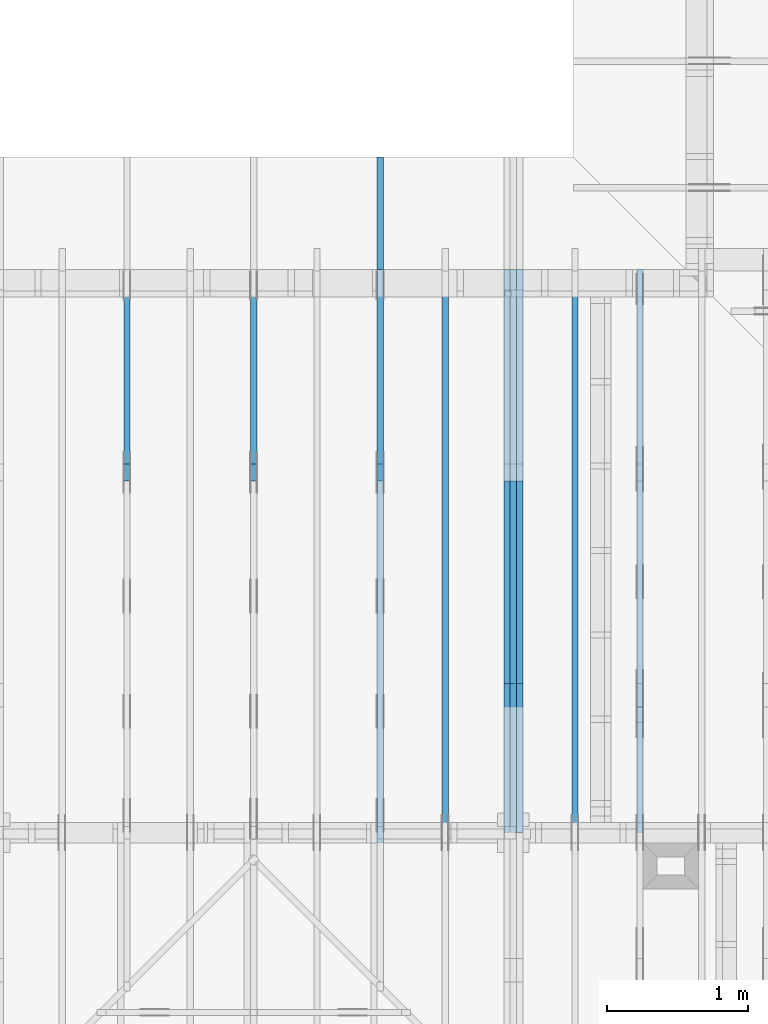
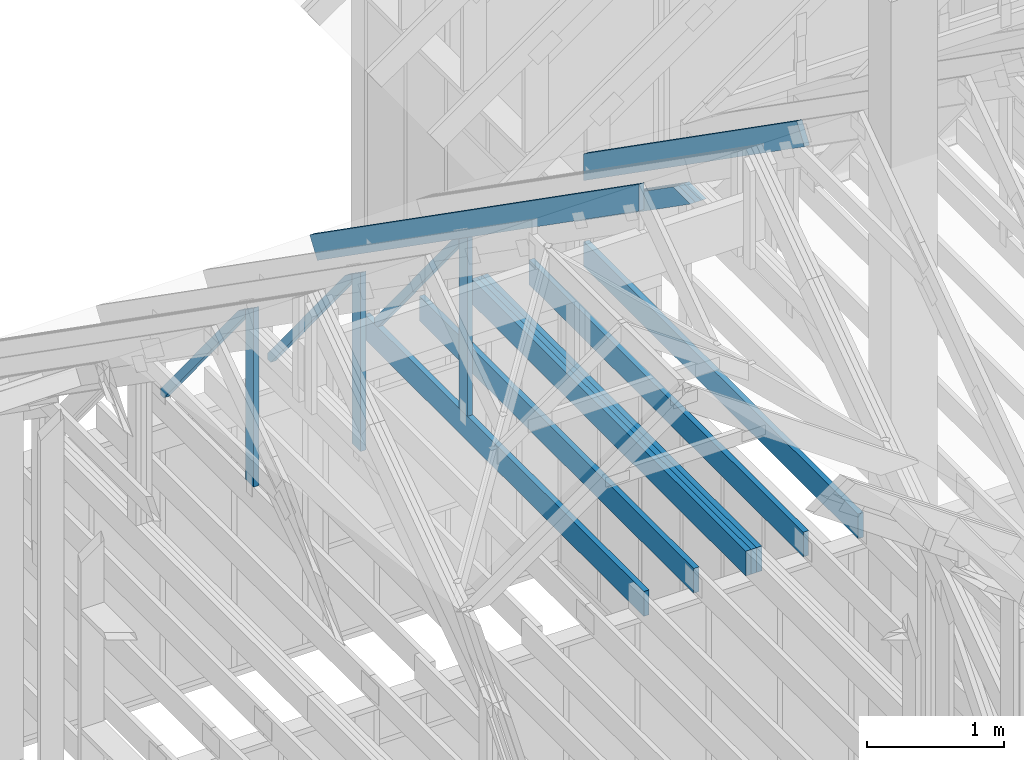
# One storey, part 17 of 70: 18 members, 7 elements without a shape of their own.
"""IFC2X3 building model written with IfcOpenShell, lengths in millimetres."""

from ifc_helpers import new_model, si_unit, frame, origin, origin_with_axes, origin_2d, place, context, project, spatial, faceted_brep, element, aggregate, save


model = new_model("IFC2X3")

# Units and contexts
model_context = context("Model", 3, precision=1e-05, world=origin())
plan_context = context("Plan", 2, precision=1e-05, world=origin_2d())
ifc_project = project(units=[si_unit("LENGTHUNIT", "METRE", prefix="MILLI"), si_unit("AREAUNIT", "SQUARE_METRE"), si_unit("VOLUMEUNIT", "CUBIC_METRE"), si_unit("SOLIDANGLEUNIT", "STERADIAN"), si_unit("PLANEANGLEUNIT", "RADIAN"), si_unit("MASSUNIT", "GRAM"), si_unit("TIMEUNIT", "SECOND"), si_unit("THERMODYNAMICTEMPERATUREUNIT", "DEGREE_CELSIUS"), si_unit("LUMINOUSINTENSITYUNIT", "LUMEN")], contexts=[model_context, plan_context])

# Site, building, storey
site_placement = place(None, origin_with_axes())
site = spatial("IfcSite", under=ifc_project, at=site_placement, CompositionType="ELEMENT")
building_placement = place(site_placement, origin_with_axes())
building = spatial("IfcBuilding", under=site, at=building_placement, Name="Layout 1", CompositionType="ELEMENT")
storey_placement = place(building_placement, origin_with_axes())
storey = spatial("IfcBuildingStorey", under=building, at=storey_placement, Name="Storey 1", CompositionType="ELEMENT", Elevation=0.0)

# Assembly, members
assembly_1_placement = place(storey_placement, frame((5660.000000000293, 8000.0, 9.122500660690286e-13), z_axis=(-1.0, 1.836909530733566e-16, 6.123031769111886e-17), x_axis=(-1.836909530733566e-16, -1.0, 0.0)))
assembly_1 = element("IfcElementAssembly", 1, at=assembly_1_placement, inside=storey, Name="T11", AssemblyPlace="FACTORY", PredefinedType="TRUSS")
member_1_placement = place(assembly_1_placement, frame((3999.9999999999995, 219.99999999999994, -90.0), z_axis=(0.0, 0.0, 1.0), x_axis=(-1.0, 1.2246063538223773e-16, 0.0)))
member_1 = element("IfcMember", 2, at=member_1_placement, Name="B3", context=model_context, shape_type="Brep", body=[
    faceted_brep([(3999.9999999999995, 220.00000000000043, 45.0), (0.0, 220.00000000000043, 45.0), (0.0, 0.0, 45.0), (4000.0, 0.0, 45.0), (0.0, 220.00000000000043, 0.0), (3999.9999999999995, 220.00000000000043, 4.898425415289508e-13), (4000.0, 0.0, 4.898425415289509e-13), (0.0, 0.0, 0.0), (0.0, 0.0, 0.0), (2.755364296100349e-15, -3.3742366240998092e-31, 45.0), (2.969670408019265e-14, 220.0, 45.0), (2.69413397840923e-14, 220.0, -1.6496267940043512e-30), (4000.0, -7.347638122934264e-13, 7.109387612088872e-29), (4000.0, -7.32008447997326e-13, 45.0), (5.061354936149714e-31, 2.755364296100349e-15, 45.0), (0.0, 0.0, 0.0), (4000.0, 220.00000000000043, 5.048709793414476e-29), (4000.0, 220.00000000000043, 45.0), (4000.0, 4.263256414560601e-13, 45.0), (4000.0, 4.263256414560601e-13, 0.0), (0.0, 220.0, 0.0), (0.0, 220.0, 45.0), (3999.9999999999995, 220.00000000000065, 45.0), (3999.9999999999995, 220.00000000000065, 1.262177448353619e-29)], [[[0, 1, 2, 3]], [[4, 5, 6, 7]], [[8, 9, 10, 11]], [[12, 13, 14, 15]], [[16, 17, 18, 19]], [[20, 21, 22, 23]]]),
])
member_2_placement = place(assembly_1_placement, frame((3999.9999999999995, 219.99999999999994, -135.0), z_axis=(0.0, 0.0, 1.0), x_axis=(-1.0, 1.2246063538223773e-16, 0.0)))
member_2 = element("IfcMember", 3, at=member_2_placement, Name="B3", context=model_context, shape_type="Brep", body=[
    faceted_brep([(3999.9999999999995, 220.00000000000043, 45.0), (0.0, 220.00000000000043, 45.0), (0.0, 0.0, 45.0), (4000.0, 0.0, 45.0), (0.0, 220.00000000000043, 0.0), (3999.9999999999995, 220.00000000000043, 4.898425415289508e-13), (4000.0, 0.0, 4.898425415289509e-13), (0.0, 0.0, 0.0), (0.0, 0.0, 0.0), (2.755364296100349e-15, -3.3742366240998092e-31, 45.0), (2.969670408019265e-14, 220.0, 45.0), (2.69413397840923e-14, 220.0, -1.6496267940043512e-30), (4000.0, -7.347638122934264e-13, 7.109387612088872e-29), (4000.0, -7.32008447997326e-13, 45.0), (5.061354936149714e-31, 2.755364296100349e-15, 45.0), (0.0, 0.0, 0.0), (4000.0, 220.00000000000043, 5.048709793414476e-29), (4000.0, 220.00000000000043, 45.0), (4000.0, 4.263256414560601e-13, 45.0), (4000.0, 4.263256414560601e-13, 0.0), (0.0, 220.0, 0.0), (0.0, 220.0, 45.0), (3999.9999999999995, 220.00000000000065, 45.0), (3999.9999999999995, 220.00000000000065, 1.262177448353619e-29)], [[[0, 1, 2, 3]], [[4, 5, 6, 7]], [[8, 9, 10, 11]], [[12, 13, 14, 15]], [[16, 17, 18, 19]], [[20, 21, 22, 23]]]),
])
member_3_placement = place(assembly_1_placement, frame((3999.9999999999995, 219.99999999999994, -180.0), z_axis=(0.0, 0.0, 1.0), x_axis=(-1.0, 1.2246063538223773e-16, 0.0)))
member_3 = element("IfcMember", 4, at=member_3_placement, Name="B3", context=model_context, shape_type="Brep", body=[
    faceted_brep([(3999.9999999999995, 220.00000000000043, 45.0), (0.0, 220.00000000000043, 45.0), (0.0, 0.0, 45.0), (4000.0, 0.0, 45.0), (0.0, 220.00000000000043, 0.0), (3999.9999999999995, 220.00000000000043, 4.898425415289508e-13), (4000.0, 0.0, 4.898425415289509e-13), (0.0, 0.0, 0.0), (0.0, 0.0, 0.0), (2.755364296100349e-15, -3.3742366240998092e-31, 45.0), (2.969670408019265e-14, 220.0, 45.0), (2.69413397840923e-14, 220.0, -1.6496267940043512e-30), (4000.0, -7.347638122934264e-13, 7.109387612088872e-29), (4000.0, -7.32008447997326e-13, 45.0), (5.061354936149714e-31, 2.755364296100349e-15, 45.0), (0.0, 0.0, 0.0), (4000.0, 220.00000000000043, 5.048709793414476e-29), (4000.0, 220.00000000000043, 45.0), (4000.0, 4.263256414560601e-13, 45.0), (4000.0, 4.263256414560601e-13, 0.0), (0.0, 220.0, 0.0), (0.0, 220.0, 45.0), (3999.9999999999995, 220.00000000000065, 45.0), (3999.9999999999995, 220.00000000000065, 1.262177448353619e-29)], [[[0, 1, 2, 3]], [[4, 5, 6, 7]], [[8, 9, 10, 11]], [[12, 13, 14, 15]], [[16, 17, 18, 19]], [[20, 21, 22, 23]]]),
])
member_4_placement = place(assembly_1_placement, frame((1500.0000000016348, 1635.2479471379418, -90.0), z_axis=(0.0, 0.0, 1.0), x_axis=(0.8191520442886182, 0.57357643635158, 0.0)))
member_4 = element("IfcMember", 5, at=member_4_placement, Name="SC5", context=model_context, shape_type="Brep", body=[
    faceted_brep([(1858.470709186502, 144.99999999999932, 45.0), (101.53009304079887, 144.99999999999932, 45.0), (0.0, 8.753886504564434e-12, 45.0), (2065.5521701640737, 8.753886504564434e-12, 45.0), (101.53009304079887, 144.99999999999932, 1.2433439704193942e-14), (1858.470709186502, 144.99999999999932, 2.27589503886257e-13), (2065.5521701640737, 8.753886504564434e-12, 2.529488311734525e-13), (0.0, 8.753886504564434e-12, 0.0), (3.760981837651581e-15, 8.751253036730632e-12, -2.8112743459008187e-31), (6.0180441335604696e-15, 8.749672624696822e-12, 45.0), (101.53009304079885, 145.00000000001066, 45.0), (101.53009304079885, 145.00000000001066, 1.0796763268234844e-30), (2065.5521701640737, 1.0361478085862912e-12, -6.344365949469521e-29), (2065.5521701640737, 1.0389031728823915e-12, 45.0), (1.0295155918449194e-29, 8.756641868860535e-12, 45.0), (0.0, 8.753886504564434e-12, 0.0), (1858.470709186502, 144.9999999999992, 1.262177448353619e-29), (1858.470709186502, 144.9999999999992, 45.0), (2065.5521701640737, 0.0, 45.0), (2065.5521701640737, 0.0, 1.262177448353619e-29), (101.53009304079887, 145.0000000000107, -1.5777218104420236e-30), (101.53009304079887, 145.0000000000107, 45.0), (1858.470709186502, 144.99999999999926, 45.0), (1858.470709186502, 144.99999999999926, -4.733165431326071e-30)], [[[0, 1, 2, 3]], [[4, 5, 6, 7]], [[8, 9, 10, 11]], [[12, 13, 14, 15]], [[16, 17, 18, 19]], [[20, 21, 22, 23]]]),
])
member_5_placement = place(assembly_1_placement, frame((1500.0000000016348, 1635.2479471379418, -135.00000000000003), z_axis=(0.0, 0.0, 1.0), x_axis=(0.8191520442886182, 0.57357643635158, 0.0)))
member_5 = element("IfcMember", 6, at=member_5_placement, Name="SC5", context=model_context, shape_type="Brep", body=[
    faceted_brep([(1858.470709186502, 144.99999999999932, 45.0), (101.53009304079887, 144.99999999999932, 45.0), (0.0, 8.753886504564434e-12, 45.0), (2065.5521701640737, 8.753886504564434e-12, 45.0), (101.53009304079887, 144.99999999999932, 1.2433439704193942e-14), (1858.470709186502, 144.99999999999932, 2.27589503886257e-13), (2065.5521701640737, 8.753886504564434e-12, 2.529488311734525e-13), (0.0, 8.753886504564434e-12, 0.0), (3.760981837651581e-15, 8.751253036730632e-12, -2.8112743459008187e-31), (6.0180441335604696e-15, 8.749672624696822e-12, 45.0), (101.53009304079885, 145.00000000001066, 45.0), (101.53009304079885, 145.00000000001066, 1.0796763268234844e-30), (2065.5521701640737, 1.0361478085862912e-12, -6.344365949469521e-29), (2065.5521701640737, 1.0389031728823915e-12, 45.0), (1.0295155918449194e-29, 8.756641868860535e-12, 45.0), (0.0, 8.753886504564434e-12, 0.0), (1858.470709186502, 144.9999999999992, 1.262177448353619e-29), (1858.470709186502, 144.9999999999992, 45.0), (2065.5521701640737, 0.0, 45.0), (2065.5521701640737, 0.0, 1.262177448353619e-29), (101.53009304079887, 145.0000000000107, -1.5777218104420236e-30), (101.53009304079887, 145.0000000000107, 45.0), (1858.470709186502, 144.99999999999926, 45.0), (1858.470709186502, 144.99999999999926, -4.733165431326071e-30)], [[[0, 1, 2, 3]], [[4, 5, 6, 7]], [[8, 9, 10, 11]], [[12, 13, 14, 15]], [[16, 17, 18, 19]], [[20, 21, 22, 23]]]),
])
member_6_placement = place(assembly_1_placement, frame((1500.0000000016348, 1635.2479471379418, -180.0), z_axis=(0.0, 0.0, 1.0), x_axis=(0.8191520442886182, 0.57357643635158, 0.0)))
member_6 = element("IfcMember", 7, at=member_6_placement, Name="SC5", context=model_context, shape_type="Brep", body=[
    faceted_brep([(1858.470709186502, 144.99999999999932, 45.0), (101.53009304079887, 144.99999999999932, 45.0), (0.0, 8.753886504564434e-12, 45.0), (2065.5521701640737, 8.753886504564434e-12, 45.0), (101.53009304079887, 144.99999999999932, 1.2433439704193942e-14), (1858.470709186502, 144.99999999999932, 2.27589503886257e-13), (2065.5521701640737, 8.753886504564434e-12, 2.529488311734525e-13), (0.0, 8.753886504564434e-12, 0.0), (3.760981837651581e-15, 8.751253036730632e-12, -2.8112743459008187e-31), (6.0180441335604696e-15, 8.749672624696822e-12, 45.0), (101.53009304079885, 145.00000000001066, 45.0), (101.53009304079885, 145.00000000001066, 1.0796763268234844e-30), (2065.5521701640737, 1.0361478085862912e-12, -6.344365949469521e-29), (2065.5521701640737, 1.0389031728823915e-12, 45.0), (1.0295155918449194e-29, 8.756641868860535e-12, 45.0), (0.0, 8.753886504564434e-12, 0.0), (1858.470709186502, 144.9999999999992, 1.262177448353619e-29), (1858.470709186502, 144.9999999999992, 45.0), (2065.5521701640737, 0.0, 45.0), (2065.5521701640737, 0.0, 1.262177448353619e-29), (101.53009304079887, 145.0000000000107, -1.5777218104420236e-30), (101.53009304079887, 145.0000000000107, 45.0), (1858.470709186502, 144.99999999999926, 45.0), (1858.470709186502, 144.99999999999926, -4.733165431326071e-30)], [[[0, 1, 2, 3]], [[4, 5, 6, 7]], [[8, 9, 10, 11]], [[12, 13, 14, 15]], [[16, 17, 18, 19]], [[20, 21, 22, 23]]]),
])
aggregate(assembly_1, [member_1, member_2, member_3, member_4, member_5, member_6])

# Assembly, member
assembly_2_placement = place(storey_placement, frame((5266.250000000146, 8000.0, 1.3776821480501744e-15), z_axis=(-1.0, 1.836909530733566e-16, 6.123031769111886e-17), x_axis=(-1.836909530733566e-16, -1.0, 0.0)))
assembly_2 = element("IfcElementAssembly", 8, at=assembly_2_placement, inside=storey, Name="MB1", AssemblyPlace="FACTORY", PredefinedType="TRUSS")
member_7_placement = place(assembly_2_placement, frame((4000.0000000000005, 219.99999999999997, -45.0), z_axis=(0.0, 0.0, 1.0), x_axis=(-1.0, 1.2246063538223773e-16, 0.0)))
member_7 = element("IfcMember", 9, at=member_7_placement, Name="B3", context=model_context, shape_type="Brep", body=[
    faceted_brep([(4000.0000000000005, 220.00000000000045, 45.0), (0.0, 220.00000000000045, 45.0), (0.0, 0.0, 45.0), (4000.0000000000005, 0.0, 45.0), (0.0, 220.00000000000045, 0.0), (4000.0000000000005, 220.00000000000045, 4.89842541528951e-13), (4000.0000000000005, 0.0, 4.89842541528951e-13), (0.0, 0.0, 0.0), (0.0, 0.0, 0.0), (2.755364296100349e-15, -3.3742366240998092e-31, 45.0), (2.969670408019265e-14, 220.0, 45.0), (2.69413397840923e-14, 220.0, -1.6496267940043512e-30), (4000.0000000000005, -7.347638122934265e-13, 7.283414641863702e-29), (4000.0000000000005, -7.320084479973261e-13, 45.0), (5.061354936149714e-31, 2.755364296100349e-15, 45.0), (0.0, 0.0, 0.0), (4000.0000000000005, 220.00000000000045, 0.0), (4000.0000000000005, 220.00000000000045, 45.0), (4000.0000000000005, 4.547473508864641e-13, 45.0), (4000.0000000000005, 4.547473508864641e-13, 0.0), (0.0, 220.0, 0.0), (0.0, 220.0, 45.0), (4000.0000000000005, 220.00000000000065, 45.0), (4000.0000000000005, 220.00000000000065, 1.1044052673094165e-29)], [[[0, 1, 2, 3]], [[4, 5, 6, 7]], [[8, 9, 10, 11]], [[12, 13, 14, 15]], [[16, 17, 18, 19]], [[20, 21, 22, 23]]]),
])
aggregate(assembly_2, [member_7])

assembly_3_placement = place(storey_placement, frame((6188.750000000146, 8000.0, 1.3776821480501744e-15), z_axis=(-1.0, 1.836909530733566e-16, 6.123031769111886e-17), x_axis=(-1.836909530733566e-16, -1.0, 0.0)))
assembly_3 = element("IfcElementAssembly", 10, at=assembly_3_placement, inside=storey, Name="MB1", AssemblyPlace="FACTORY", PredefinedType="TRUSS")
member_8_placement = place(assembly_3_placement, frame((4000.0000000000005, 219.99999999999997, -45.0), z_axis=(0.0, 0.0, 1.0), x_axis=(-1.0, 1.2246063538223773e-16, 0.0)))
member_8 = element("IfcMember", 11, at=member_8_placement, Name="B3", context=model_context, shape_type="Brep", body=[
    faceted_brep([(4000.0000000000005, 220.00000000000045, 45.0), (0.0, 220.00000000000045, 45.0), (0.0, 0.0, 45.0), (4000.0000000000005, 0.0, 45.0), (0.0, 220.00000000000045, 0.0), (4000.0000000000005, 220.00000000000045, 4.89842541528951e-13), (4000.0000000000005, 0.0, 4.89842541528951e-13), (0.0, 0.0, 0.0), (0.0, 0.0, 0.0), (2.755364296100349e-15, -3.3742366240998092e-31, 45.0), (2.969670408019265e-14, 220.0, 45.0), (2.69413397840923e-14, 220.0, -1.6496267940043512e-30), (4000.0000000000005, -7.347638122934265e-13, 7.283414641863702e-29), (4000.0000000000005, -7.320084479973261e-13, 45.0), (5.061354936149714e-31, 2.755364296100349e-15, 45.0), (0.0, 0.0, 0.0), (4000.0000000000005, 220.00000000000045, 0.0), (4000.0000000000005, 220.00000000000045, 45.0), (4000.0000000000005, 4.547473508864641e-13, 45.0), (4000.0000000000005, 4.547473508864641e-13, 0.0), (0.0, 220.0, 0.0), (0.0, 220.0, 45.0), (4000.0000000000005, 220.00000000000065, 45.0), (4000.0000000000005, 220.00000000000065, 1.1044052673094165e-29)], [[[0, 1, 2, 3]], [[4, 5, 6, 7]], [[8, 9, 10, 11]], [[12, 13, 14, 15]], [[16, 17, 18, 19]], [[20, 21, 22, 23]]]),
])
aggregate(assembly_3, [member_8])

# Assembly, members
assembly_4_placement = place(storey_placement, frame((6650.000000000001, 8000.0, -9.081170196248781e-13), z_axis=(-1.0, 1.836909530733566e-16, 6.123031769111886e-17), x_axis=(-1.836909530733566e-16, -1.0, 0.0)))
assembly_4 = element("IfcElementAssembly", 12, at=assembly_4_placement, inside=storey, Name="T12", AssemblyPlace="FACTORY", PredefinedType="TRUSS")
member_9_placement = place(assembly_4_placement, frame((5.684341886080802e-14, 761.948955193162, -45.0), z_axis=(0.0, 0.0, 1.0), x_axis=(0.8191520442889915, 0.5735764363510465, 0.0)))
member_9 = element("IfcMember", 13, at=member_9_placement, Name="T12", context=model_context, shape_type="Brep", body=[
    faceted_brep([(3928.0746244414318, 195.00000000097384, 45.0), (136.5404699499494, 195.00000000097384, 45.0), (0.0, 0.0, 45.0), (3928.0746244410616, 0.0, 45.0), (136.5404699499494, 195.00000000097384, 1.672083270546014e-14), (3928.0746244414318, 195.00000000097384, 4.810345143379426e-13), (3928.0746244410616, 0.0, 4.810345143378973e-13), (0.0, 0.0, 0.0), (0.0, 0.0, 0.0), (2.2570622959115e-15, -1.5804120338061464e-15, 45.0), (136.54046994994928, 194.99999999865173, 45.0), (136.54046994994928, 194.99999999865173, 7.099748146989106e-30), (3928.0746244410616, 1.0005729774873576e-09, 1.174126574786272e-28), (3928.0746244410616, 1.0005757328516537e-09, 45.0), (-7.018560799882405e-28, 2.755364296100349e-15, 45.0), (0.0, 0.0, 0.0), (3928.0746244410616, 195.00000000097384, -2.2668706972430995e-26), (3928.0746244410616, 195.00000000097384, 45.0), (3928.0746244410616, 1.0024905350292102e-09, 45.0), (3928.0746244410616, 1.0024905350292102e-09, 0.0), (136.5404699499494, 194.9999999986517, 1.5777218104420236e-30), (136.5404699499494, 194.9999999986517, 45.0), (3928.0746244414318, 195.00000000097424, 45.0), (3928.0746244414318, 195.00000000097424, 2.3665827156630354e-29)], [[[0, 1, 2, 3]], [[4, 5, 6, 7]], [[8, 9, 10, 11]], [[12, 13, 14, 15]], [[16, 17, 18, 19]], [[20, 21, 22, 23]]]),
])
member_10_placement = place(assembly_4_placement, frame((3999.9999999999995, 220.0, -45.0), z_axis=(0.0, 0.0, 1.0), x_axis=(-1.0, 1.2246063538223773e-16, 0.0)))
member_10 = element("IfcMember", 14, at=member_10_placement, Name="B3", context=model_context, shape_type="Brep", body=[
    faceted_brep([(3999.9999999999995, 220.00000000000048, 45.0), (0.0, 220.00000000000048, 45.0), (0.0, 0.0, 45.0), (4000.0, 0.0, 45.0), (0.0, 220.00000000000048, 0.0), (3999.9999999999995, 220.00000000000048, 4.898425415289508e-13), (4000.0, 0.0, 4.898425415289509e-13), (0.0, 0.0, 0.0), (0.0, 0.0, 0.0), (2.755364296100349e-15, -3.3742366240998092e-31, 45.0), (2.969670408019265e-14, 220.0, 45.0), (2.69413397840923e-14, 220.0, -1.6496267940043512e-30), (4000.0, -7.347638122934264e-13, 7.457441671638533e-29), (4000.0, -7.32008447997326e-13, 45.0), (5.061354936149714e-31, 2.755364296100349e-15, 45.0), (0.0, 0.0, 0.0), (4000.0, 220.00000000000048, 5.048709793414476e-29), (4000.0, 220.00000000000048, 45.0), (4000.0, 4.831690603168681e-13, 45.0), (4000.0, 4.831690603168681e-13, 0.0), (0.0, 220.0, 0.0), (0.0, 220.0, 45.0), (3999.9999999999995, 220.00000000000065, 45.0), (3999.9999999999995, 220.00000000000065, 9.466330862652142e-30)], [[[0, 1, 2, 3]], [[4, 5, 6, 7]], [[8, 9, 10, 11]], [[12, 13, 14, 15]], [[16, 17, 18, 19]], [[20, 21, 22, 23]]]),
])
aggregate(assembly_4, [member_9, member_10])

assembly_5_placement = place(storey_placement, frame((4805.0, 8000.000000000001, -4.5336966873841394e-13), z_axis=(-1.0, 1.836909530733566e-16, 6.123031769111886e-17), x_axis=(-1.836909530733566e-16, -1.0, 0.0)))
assembly_5 = element("IfcElementAssembly", 15, at=assembly_5_placement, inside=storey, Name="T1", AssemblyPlace="FACTORY", PredefinedType="TRUSS")
member_11_placement = place(assembly_5_placement, frame((-688.1525949109839, 280.09932079477335, -45.0), z_axis=(0.0, 0.0, 1.0), x_axis=(0.8191520442889916, 0.5735764363510464, 0.0)))
member_11 = element("IfcMember", 16, at=member_11_placement, Name="T7", context=model_context, shape_type="Brep", body=[
    faceted_brep([(5859.718026055497, 195.00000000170348, 45.0), (0.0, 195.00000000170348, 45.0), (3.9250380723387934e-10, 4.743014869745821e-10, 45.0), (5723.177556103411, 4.743014869745821e-10, 45.0), (0.0, 195.00000000170348, 0.0), (5859.718026055497, 195.00000000170348, 7.17584792631508e-13), (5723.177556103411, 4.743014869745821e-10, 7.008639599257862e-13), (3.9250380723387934e-10, 4.743014869745821e-10, 4.806626562380822e-26), (3.9250380723387955e-10, 4.743014869745821e-10, -1.4349296274686127e-41), (3.9250656259817565e-10, 4.743014869745821e-10, 45.0), (7.10441081636244e-14, 195.00000000097975, 45.0), (6.828874386752406e-14, 195.00000000097975, -4.1813414817381065e-30), (5723.177556103411, -4.570871924930312e-12, 2.7987594008890623e-28), (5723.177556103411, -4.5681165606342115e-12, 45.0), (3.925038072338793e-10, 4.743042423388779e-10, 45.0), (3.925038072338793e-10, 4.743014869745818e-10, 1.7219155529623352e-41), (5859.718026055498, 195.00000000170212, 5.048709793414476e-29), (5859.718026055498, 195.00000000170212, 45.0), (5723.177556103412, -9.094947017729282e-13, 45.0), (5723.177556103412, -9.094947017729282e-13, 5.048709793414476e-29), (0.0, 195.00000000097975, 0.0), (0.0, 195.00000000097975, 45.0), (5859.718026055498, 195.00000000170542, 45.0), (5859.718026055498, 195.00000000170542, 1.199068575935938e-28)], [[[0, 1, 2, 3]], [[4, 5, 6, 7]], [[8, 9, 10, 11]], [[12, 13, 14, 15]], [[16, 17, 18, 19]], [[20, 21, 22, 23]]]),
])
member_12_placement = place(assembly_5_placement, frame((4072.5, 220.0, -45.0), z_axis=(0.0, 0.0, 1.0), x_axis=(-1.0, 1.2246063538223773e-16, 0.0)))
member_12 = element("IfcMember", 17, at=member_12_placement, Name="B2", context=model_context, shape_type="Brep", body=[
    faceted_brep([(4072.5, 220.0000000000005, 45.0), (0.0, 220.0000000000005, 45.0), (0.0, 0.0, 45.0), (4072.5000000000005, 0.0, 45.0), (0.0, 220.0000000000005, 0.0), (4072.5, 220.0000000000005, 4.987209375941631e-13), (4072.5000000000005, 0.0, 4.987209375941632e-13), (0.0, 0.0, 0.0), (0.0, 0.0, 0.0), (2.755364296100349e-15, -3.3742366240998092e-31, 45.0), (2.969670408019265e-14, 220.0, 45.0), (2.69413397840923e-14, 220.0, -1.6496267940043512e-30), (4072.5000000000005, -7.480814063912448e-13, 7.713012753162442e-29), (4072.5000000000005, -7.453260420951445e-13, 45.0), (5.061354936149714e-31, 2.755364296100349e-15, 45.0), (0.0, 0.0, 0.0), (4072.5000000000005, 220.0000000000005, 5.048709793414476e-29), (4072.5000000000005, 220.0000000000005, 45.0), (4072.5000000000005, 5.115907697472721e-13, 45.0), (4072.5000000000005, 5.115907697472721e-13, 0.0), (0.0, 220.0, 0.0), (0.0, 220.0, 45.0), (4072.5, 220.00000000000065, 45.0), (4072.5, 220.00000000000065, 7.888609052210118e-30)], [[[0, 1, 2, 3]], [[4, 5, 6, 7]], [[8, 9, 10, 11]], [[12, 13, 14, 15]], [[16, 17, 18, 19]], [[20, 21, 22, 23]]]),
])
member_13_placement = place(assembly_5_placement, frame((1380.0000000018192, 1812.2602625085638, -45.0), z_axis=(0.0, 0.0, 1.0), x_axis=(-1.836909530733566e-16, -1.0, 0.0)))
member_13 = element("IfcMember", 18, at=member_13_placement, Name="R1", context=model_context, shape_type="Brep", body=[
    faceted_brep([(1592.2602625085638, 120.00000000001455, 45.0), (0.0, 120.00000000001455, 45.0), (84.02490458526881, 1.432454155292362e-11, 45.0), (1592.2602625085638, 1.432454155292362e-11, 45.0), (0.0, 120.00000000001455, 0.0), (1592.2602625085638, 120.00000000001455, 1.9498920344068735e-13), (1592.2602625085638, 1.432454155292362e-11, 1.9498920344068735e-13), (84.02490458526881, 1.432454155292362e-11, 1.0289743203443919e-14), (84.0249045852688, 1.4303225270850817e-11, 1.5777218104420236e-30), (84.02490458526881, 1.4303225270850817e-11, 45.0), (2.1316282072803006e-14, 120.00000000001435, 45.0), (2.1316282072803006e-14, 120.00000000001435, -2.3665827156630354e-30), (1592.2602625085638, -7.262347142616226e-13, 4.446758227255812e-29), (1592.2602625085638, -7.234793499655223e-13, 45.0), (84.02490458526881, 1.4288972904488156e-11, 45.0), (84.02490458526881, 1.4286217540192056e-11, 2.3465914747521543e-30), (1592.2602625085638, 120.00000000001455, 0.0), (1592.2602625085638, 120.00000000001455, 45.0), (1592.2602625085638, 0.0, 45.0), (1592.2602625085638, 0.0, 0.0), (0.0, 120.00000000001432, 0.0), (0.0, 120.00000000001432, 45.0), (1592.2602625085638, 120.00000000001458, 45.0), (1592.2602625085638, 120.00000000001458, 1.5777218104420236e-30)], [[[0, 1, 2, 3]], [[4, 5, 6, 7]], [[8, 9, 10, 11]], [[12, 13, 14, 15]], [[16, 17, 18, 19]], [[20, 21, 22, 23]]]),
])
member_14_placement = place(assembly_5_placement, frame((1352.9202015903857, 1750.4093182819945, -45.0), z_axis=(0.0, 0.0, 1.0), x_axis=(-0.6335417245359891, -0.7737085260432154, 0.0)))
member_14 = element("IfcMember", 19, at=member_14_placement, Name="W8", context=model_context, shape_type="Brep", body=[
    faceted_brep([(1920.699265347725, 70.00000000000026, 45.0), (42.743512167902736, 70.00000000000026, 45.0), (0.0, 34.99999999991678, 45.0), (124.61590173870172, 0.0, 45.0), (1906.6150733432037, 0.0, 45.0), (1949.3585855093766, 34.99999999991678, 45.0), (42.743512167902736, 70.00000000000026, 5.234397658549778e-15), (1920.699265347725, 70.00000000000026, 2.352100524126796e-13), (1949.3585855093766, 34.99999999991678, 2.387196909692984e-13), (1906.6150733432037, 0.0, 2.334852933109605e-13), (124.61590173870172, 0.0, 1.5260542505651917e-14), (0.0, 34.99999999991678, 0.0), (0.0, 34.99999999991678, 1.9721522630525295e-31), (0.0, 34.99999999991678, 45.0), (42.743512167902736, 70.00000000000068, 45.0), (42.743512167902736, 70.00000000000068, 1.9721522630525295e-31), (124.61590173870174, 1.4210854715202004e-14, -1.1832913578315177e-30), (124.61590173870174, 1.4210854715202004e-14, 45.0), (-1.7763568394002505e-15, 34.99999999991678, 45.0), (-1.7763568394002505e-15, 34.99999999991678, 3.944304526105059e-31), (1906.6150733432037, -3.6115941711488346e-13, 3.168539248469931e-29), (1906.6150733432037, -3.584040528187831e-13, 45.0), (124.61590173870172, -3.1066926610820185e-14, 45.0), (124.61590173870172, -3.3822290906920534e-14, 2.0709496172721852e-30), (1949.358585509377, 34.99999999855936, 6.310887241768094e-29), (1949.358585509377, 34.99999999855936, 45.0), (1906.6150733432041, -7.958078640513122e-13, 45.0), (1906.6150733432041, -7.958078640513122e-13, 6.310887241768094e-29), (1920.699265347725, 70.00000000000023, -1.262177448353619e-29), (1920.699265347725, 70.00000000000023, 45.0), (1949.3585855093766, 34.99999999856027, 45.0), (1949.3585855093766, 34.99999999856027, 0.0), (42.743512167902736, 70.00000000000068, 0.0), (42.743512167902736, 70.00000000000068, 45.0), (1920.699265347725, 70.00000000000016, 45.0), (1920.699265347725, 70.00000000000016, -6.310887241768095e-30)], [[[0, 1, 2, 3, 4, 5]], [[6, 7, 8, 9, 10, 11]], [[12, 13, 14, 15]], [[16, 17, 18, 19]], [[20, 21, 22, 23]], [[24, 25, 26, 27]], [[28, 29, 30, 31]], [[32, 33, 34, 35]]]),
])
aggregate(assembly_5, [member_11, member_12, member_13, member_14])

assembly_6_placement = place(storey_placement, frame((3905.0000000000005, 8000.000000000001, -4.5336966873841394e-13), z_axis=(-1.0, 1.836909530733566e-16, 6.123031769111886e-17), x_axis=(-1.836909530733566e-16, -1.0, 0.0)))
assembly_6 = element("IfcElementAssembly", 20, at=assembly_6_placement, inside=storey, Name="T1", AssemblyPlace="FACTORY", PredefinedType="TRUSS")
member_15_placement = place(assembly_6_placement, frame((1380.0000000018192, 1812.2602625085638, -45.0), z_axis=(0.0, 0.0, 1.0), x_axis=(-1.836909530733566e-16, -1.0, 0.0)))
member_15 = element("IfcMember", 21, at=member_15_placement, Name="R1", context=model_context, shape_type="Brep", body=[
    faceted_brep([(1592.2602625085638, 120.00000000001455, 45.0), (0.0, 120.00000000001455, 45.0), (84.02490458526881, 1.432454155292362e-11, 45.0), (1592.2602625085638, 1.432454155292362e-11, 45.0), (0.0, 120.00000000001455, 0.0), (1592.2602625085638, 120.00000000001455, 1.9498920344068735e-13), (1592.2602625085638, 1.432454155292362e-11, 1.9498920344068735e-13), (84.02490458526881, 1.432454155292362e-11, 1.0289743203443919e-14), (84.0249045852688, 1.4303225270850817e-11, 1.5777218104420236e-30), (84.02490458526881, 1.4303225270850817e-11, 45.0), (2.1316282072803006e-14, 120.00000000001435, 45.0), (2.1316282072803006e-14, 120.00000000001435, -2.3665827156630354e-30), (1592.2602625085638, -7.262347142616226e-13, 4.446758227255812e-29), (1592.2602625085638, -7.234793499655223e-13, 45.0), (84.02490458526881, 1.4288972904488156e-11, 45.0), (84.02490458526881, 1.4286217540192056e-11, 2.3465914747521543e-30), (1592.2602625085638, 120.00000000001455, 0.0), (1592.2602625085638, 120.00000000001455, 45.0), (1592.2602625085638, 0.0, 45.0), (1592.2602625085638, 0.0, 0.0), (0.0, 120.00000000001432, 0.0), (0.0, 120.00000000001432, 45.0), (1592.2602625085638, 120.00000000001458, 45.0), (1592.2602625085638, 120.00000000001458, 1.5777218104420236e-30)], [[[0, 1, 2, 3]], [[4, 5, 6, 7]], [[8, 9, 10, 11]], [[12, 13, 14, 15]], [[16, 17, 18, 19]], [[20, 21, 22, 23]]]),
])
member_16_placement = place(assembly_6_placement, frame((1352.9202015903857, 1750.4093182819945, -45.0), z_axis=(0.0, 0.0, 1.0), x_axis=(-0.6335417245359891, -0.7737085260432154, 0.0)))
member_16 = element("IfcMember", 22, at=member_16_placement, Name="W8", context=model_context, shape_type="Brep", body=[
    faceted_brep([(1920.699265347725, 70.00000000000026, 45.0), (42.743512167902736, 70.00000000000026, 45.0), (0.0, 34.99999999991678, 45.0), (124.61590173870172, 0.0, 45.0), (1906.6150733432037, 0.0, 45.0), (1949.3585855093766, 34.99999999991678, 45.0), (42.743512167902736, 70.00000000000026, 5.234397658549778e-15), (1920.699265347725, 70.00000000000026, 2.352100524126796e-13), (1949.3585855093766, 34.99999999991678, 2.387196909692984e-13), (1906.6150733432037, 0.0, 2.334852933109605e-13), (124.61590173870172, 0.0, 1.5260542505651917e-14), (0.0, 34.99999999991678, 0.0), (0.0, 34.99999999991678, 1.9721522630525295e-31), (0.0, 34.99999999991678, 45.0), (42.743512167902736, 70.00000000000068, 45.0), (42.743512167902736, 70.00000000000068, 1.9721522630525295e-31), (124.61590173870174, 1.4210854715202004e-14, -1.1832913578315177e-30), (124.61590173870174, 1.4210854715202004e-14, 45.0), (-1.7763568394002505e-15, 34.99999999991678, 45.0), (-1.7763568394002505e-15, 34.99999999991678, 3.944304526105059e-31), (1906.6150733432037, -3.6115941711488346e-13, 3.168539248469931e-29), (1906.6150733432037, -3.584040528187831e-13, 45.0), (124.61590173870172, -3.1066926610820185e-14, 45.0), (124.61590173870172, -3.3822290906920534e-14, 2.0709496172721852e-30), (1949.358585509377, 34.99999999855936, 6.310887241768094e-29), (1949.358585509377, 34.99999999855936, 45.0), (1906.6150733432041, -7.958078640513122e-13, 45.0), (1906.6150733432041, -7.958078640513122e-13, 6.310887241768094e-29), (1920.699265347725, 70.00000000000023, -1.262177448353619e-29), (1920.699265347725, 70.00000000000023, 45.0), (1949.3585855093766, 34.99999999856027, 45.0), (1949.3585855093766, 34.99999999856027, 0.0), (42.743512167902736, 70.00000000000068, 0.0), (42.743512167902736, 70.00000000000068, 45.0), (1920.699265347725, 70.00000000000016, 45.0), (1920.699265347725, 70.00000000000016, -6.310887241768095e-30)], [[[0, 1, 2, 3, 4, 5]], [[6, 7, 8, 9, 10, 11]], [[12, 13, 14, 15]], [[16, 17, 18, 19]], [[20, 21, 22, 23]], [[24, 25, 26, 27]], [[28, 29, 30, 31]], [[32, 33, 34, 35]]]),
])
aggregate(assembly_6, [member_15, member_16])

assembly_7_placement = place(storey_placement, frame((3005.0000000000005, 8000.0, 1.3776821480501744e-15), z_axis=(-1.0, 1.836909530733566e-16, 6.123031769111886e-17), x_axis=(-1.836909530733566e-16, -1.0, 0.0)))
assembly_7 = element("IfcElementAssembly", 23, at=assembly_7_placement, inside=storey, Name="T1", AssemblyPlace="FACTORY", PredefinedType="TRUSS")
member_17_placement = place(assembly_7_placement, frame((1380.0000000018192, 1812.2602625085638, -45.0), z_axis=(0.0, 0.0, 1.0), x_axis=(-1.836909530733566e-16, -1.0, 0.0)))
member_17 = element("IfcMember", 24, at=member_17_placement, Name="R1", context=model_context, shape_type="Brep", body=[
    faceted_brep([(1592.2602625085638, 120.00000000001455, 45.0), (0.0, 120.00000000001455, 45.0), (84.02490458526881, 1.432454155292362e-11, 45.0), (1592.2602625085638, 1.432454155292362e-11, 45.0), (0.0, 120.00000000001455, 0.0), (1592.2602625085638, 120.00000000001455, 1.9498920344068735e-13), (1592.2602625085638, 1.432454155292362e-11, 1.9498920344068735e-13), (84.02490458526881, 1.432454155292362e-11, 1.0289743203443919e-14), (84.0249045852688, 1.4303225270850817e-11, 1.5777218104420236e-30), (84.02490458526881, 1.4303225270850817e-11, 45.0), (2.1316282072803006e-14, 120.00000000001435, 45.0), (2.1316282072803006e-14, 120.00000000001435, -2.3665827156630354e-30), (1592.2602625085638, -7.262347142616226e-13, 4.446758227255812e-29), (1592.2602625085638, -7.234793499655223e-13, 45.0), (84.02490458526881, 1.4288972904488156e-11, 45.0), (84.02490458526881, 1.4286217540192056e-11, 2.3465914747521543e-30), (1592.2602625085638, 120.00000000001455, 0.0), (1592.2602625085638, 120.00000000001455, 45.0), (1592.2602625085638, 0.0, 45.0), (1592.2602625085638, 0.0, 0.0), (0.0, 120.00000000001432, 0.0), (0.0, 120.00000000001432, 45.0), (1592.2602625085638, 120.00000000001458, 45.0), (1592.2602625085638, 120.00000000001458, 1.5777218104420236e-30)], [[[0, 1, 2, 3]], [[4, 5, 6, 7]], [[8, 9, 10, 11]], [[12, 13, 14, 15]], [[16, 17, 18, 19]], [[20, 21, 22, 23]]]),
])
member_18_placement = place(assembly_7_placement, frame((1352.9202015903857, 1750.4093182819945, -45.0), z_axis=(0.0, 0.0, 1.0), x_axis=(-0.6335417245359891, -0.7737085260432154, 0.0)))
member_18 = element("IfcMember", 25, at=member_18_placement, Name="W8", context=model_context, shape_type="Brep", body=[
    faceted_brep([(1920.699265347725, 70.00000000000026, 45.0), (42.743512167902736, 70.00000000000026, 45.0), (0.0, 34.99999999991678, 45.0), (124.61590173870172, 0.0, 45.0), (1906.6150733432037, 0.0, 45.0), (1949.3585855093766, 34.99999999991678, 45.0), (42.743512167902736, 70.00000000000026, 5.234397658549778e-15), (1920.699265347725, 70.00000000000026, 2.352100524126796e-13), (1949.3585855093766, 34.99999999991678, 2.387196909692984e-13), (1906.6150733432037, 0.0, 2.334852933109605e-13), (124.61590173870172, 0.0, 1.5260542505651917e-14), (0.0, 34.99999999991678, 0.0), (0.0, 34.99999999991678, 1.9721522630525295e-31), (0.0, 34.99999999991678, 45.0), (42.743512167902736, 70.00000000000068, 45.0), (42.743512167902736, 70.00000000000068, 1.9721522630525295e-31), (124.61590173870174, 1.4210854715202004e-14, -1.1832913578315177e-30), (124.61590173870174, 1.4210854715202004e-14, 45.0), (-1.7763568394002505e-15, 34.99999999991678, 45.0), (-1.7763568394002505e-15, 34.99999999991678, 3.944304526105059e-31), (1906.6150733432037, -3.6115941711488346e-13, 3.168539248469931e-29), (1906.6150733432037, -3.584040528187831e-13, 45.0), (124.61590173870172, -3.1066926610820185e-14, 45.0), (124.61590173870172, -3.3822290906920534e-14, 2.0709496172721852e-30), (1949.358585509377, 34.99999999855936, 6.310887241768094e-29), (1949.358585509377, 34.99999999855936, 45.0), (1906.6150733432041, -7.958078640513122e-13, 45.0), (1906.6150733432041, -7.958078640513122e-13, 6.310887241768094e-29), (1920.699265347725, 70.00000000000023, -1.262177448353619e-29), (1920.699265347725, 70.00000000000023, 45.0), (1949.3585855093766, 34.99999999856027, 45.0), (1949.3585855093766, 34.99999999856027, 0.0), (42.743512167902736, 70.00000000000068, 0.0), (42.743512167902736, 70.00000000000068, 45.0), (1920.699265347725, 70.00000000000016, 45.0), (1920.699265347725, 70.00000000000016, -6.310887241768095e-30)], [[[0, 1, 2, 3, 4, 5]], [[6, 7, 8, 9, 10, 11]], [[12, 13, 14, 15]], [[16, 17, 18, 19]], [[20, 21, 22, 23]], [[24, 25, 26, 27]], [[28, 29, 30, 31]], [[32, 33, 34, 35]]]),
])
aggregate(assembly_7, [member_17, member_18])

save(model, "model.ifc")
